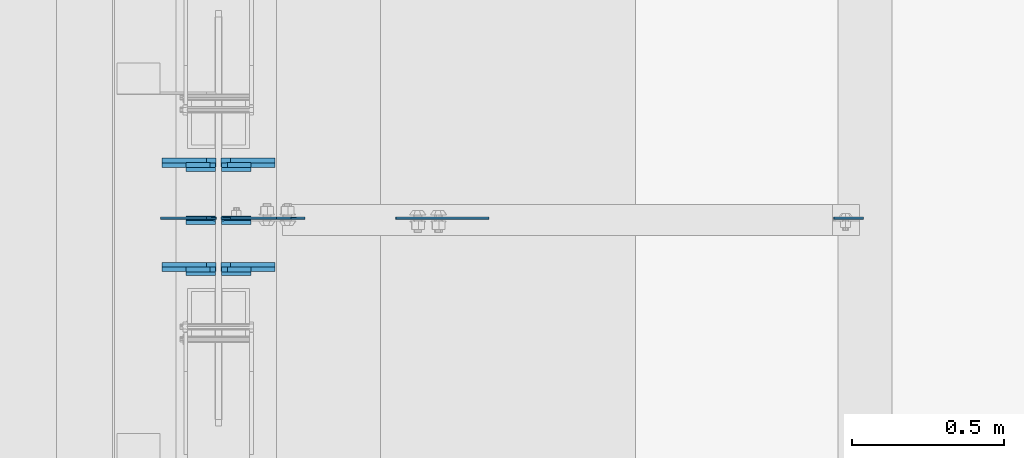
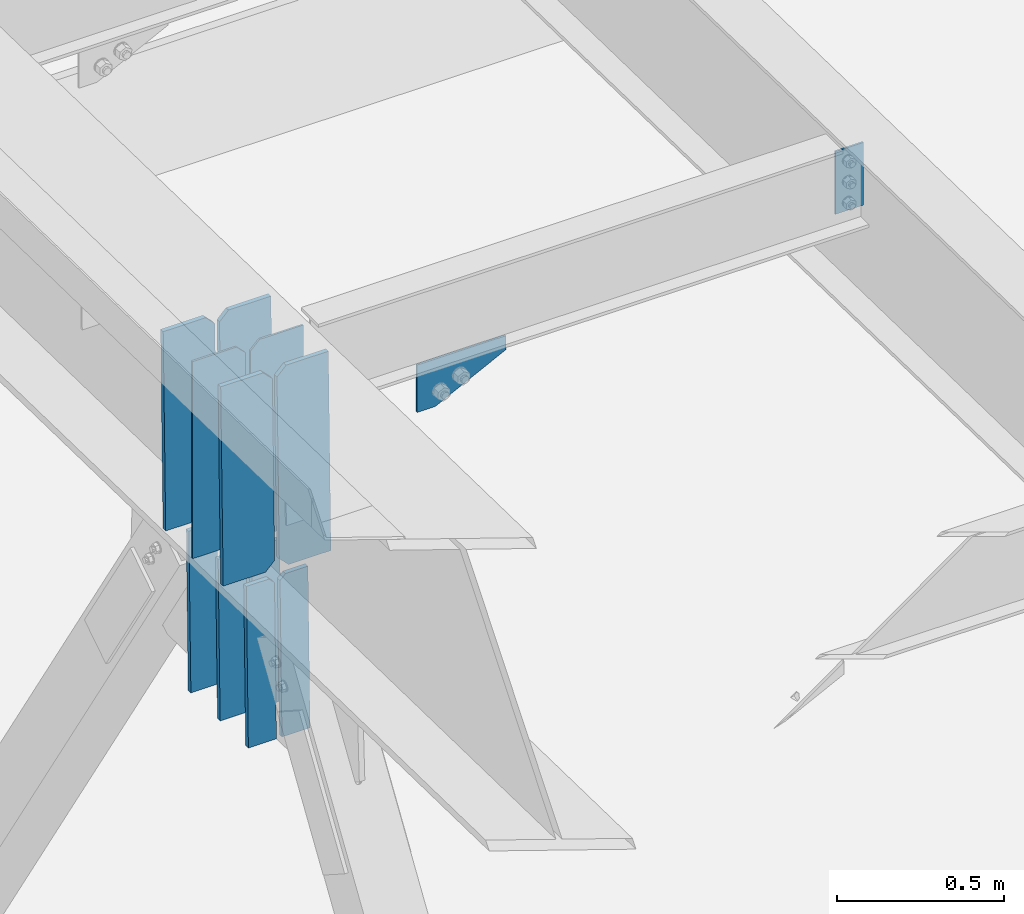
# One storey, part 1435 of 1763: 14 plates, 3 elements without a shape of their own.
"""IFC2X3 building model written with IfcOpenShell, lengths in millimetres."""

from ifc_helpers import new_model, si_unit, frame, origin_with_axes, place, context, subcontext, project, spatial, faceted_brep, material, type_object, element, aggregate, save


model = new_model("IFC2X3")

# Units and contexts
model_context = context("Model", 3, precision=1e-05, world=origin_with_axes())
body_context = subcontext(model_context, "Body", "Model", "MODEL_VIEW")
ifc_project = project(units=[si_unit("LENGTHUNIT", "METRE", prefix="MILLI"), si_unit("AREAUNIT", "SQUARE_METRE"), si_unit("VOLUMEUNIT", "CUBIC_METRE"), si_unit("MASSUNIT", "GRAM", prefix="KILO"), si_unit("TIMEUNIT", "SECOND"), si_unit("PLANEANGLEUNIT", "RADIAN"), si_unit("SOLIDANGLEUNIT", "STERADIAN"), si_unit("THERMODYNAMICTEMPERATUREUNIT", "DEGREE_CELSIUS"), si_unit("LUMINOUSINTENSITYUNIT", "LUMEN")], contexts=[model_context])

# Site, building, storey
site_placement = place(None, origin_with_axes())
site = spatial("IfcSite", under=ifc_project, at=site_placement, CompositionType="ELEMENT")
building_placement = place(site_placement, origin_with_axes())
building = spatial("IfcBuilding", under=site, at=building_placement, Name="Undefined", CompositionType="ELEMENT")
storey_placement = place(building_placement, origin_with_axes())
storey = spatial("IfcBuildingStorey", under=building, at=storey_placement, Name="Undefined", CompositionType="ELEMENT", Elevation=0.0)

# Assembly, plate
assembly_1_placement = place(storey_placement, origin_with_axes())
assembly_1 = element("IfcElementAssembly", 1, at=assembly_1_placement, inside=storey, Name="BEAM", AssemblyPlace="NOTDEFINED", PredefinedType="RIGID_FRAME")
ifc_material = material(Name="STEEL/A36")
plate_type_1 = type_object("IfcPlateType", PredefinedType="NOTDEFINED")
plate_1_placement = place(assembly_1_placement, frame((-85253.8569165555, 4502.14999998664, 11785.8655106812), z_axis=(-1.0, 0.0, 0.0), x_axis=(0.0, 0.0, -1.0)))
plate_1 = element("IfcPlate", 2, at=plate_1_placement, type_object=plate_type_1, material=ifc_material, Name="PLATE", context=body_context, shape_type="Brep", body=[
    faceted_brep([(1.81898940354586e-12, -3.17500000000291, 0.0), (0.0, -3.17499999999927, 96.8375015258789), (0.0, 3.17499999999927, 96.8375015258789), (-1.81898940354586e-12, 3.17499999997381, 0.0), (228.600006103516, -3.17499999999927, 96.8375015258789), (228.600006103516, 3.17499999999927, 96.8375015258789), (228.600006103516, -3.17500000001019, -7.27595761418343e-12), (228.600006103516, 3.17499999999563, -7.27595761418343e-12)], [[[0, 1, 2, 3]], [[1, 4, 5, 2]], [[4, 6, 7, 5]], [[6, 0, 3, 7]], [[5, 7, 3, 2]], [[6, 4, 1, 0]]]),
])
aggregate(assembly_1, [plate_1])

# Assembly, plates
assembly_2_placement = place(storey_placement, origin_with_axes())
assembly_2 = element("IfcElementAssembly", 3, at=assembly_2_placement, inside=storey, Name="BEAM", AssemblyPlace="NOTDEFINED", PredefinedType="RIGID_FRAME")
plate_type_2 = type_object("IfcPlateType", PredefinedType="NOTDEFINED")
plate_2_placement = place(assembly_2_placement, frame((-87383.6747736984, 4502.15000003567, 11077.9107555057), z_axis=(0.0, 0.0, 1.0), x_axis=(-1.0, 0.0, 0.0)))
plate_2 = element("IfcPlate", 4, at=plate_2_placement, type_object=plate_type_2, material=ifc_material, Name="PLATE", context=body_context, shape_type="Brep", body=[
    faceted_brep([(0.0, -3.17500000000291, 31.75), (0.0, -3.17499999999927, 686.812194824219), (0.0, 3.17499999999927, 686.812194824219), (0.0, 3.17500000000291, 31.75), (31.75, -3.17499999999927, 718.562194824219), (31.75, 3.17499999999927, 718.562194824219), (182.5625, -3.17499999999927, 718.562194824219), (182.5625, 3.17499999999927, 718.562194824219), (182.5625, -3.17500000000291, 0.0), (182.5625, 3.17500000000291, 0.0), (31.7499999999036, -3.17499999997381, 9.42916855706244e-11), (31.7499999998854, 3.17500000000291, 9.42916855706244e-11)], [[[0, 1, 2, 3]], [[1, 4, 5, 2]], [[4, 6, 7, 5]], [[6, 8, 9, 7]], [[8, 10, 11, 9]], [[10, 0, 3, 11]], [[5, 7, 9, 11, 3, 2]], [[10, 8, 6, 4, 1, 0]]]),
])
plate_type_3 = type_object("IfcPlateType", PredefinedType="NOTDEFINED")
plate_3_placement = place(assembly_2_placement, frame((-87367.1997736983, 4502.15000003459, 11077.9107555057), z_axis=(0.0, 0.0, 1.0), x_axis=(1.0, 0.0, 0.0)))
plate_3 = element("IfcPlate", 5, at=plate_3_placement, type_object=plate_type_3, material=ifc_material, Name="PLATE", context=body_context, shape_type="Brep", body=[
    faceted_brep([(0.0, -3.17500000000291, 31.75), (0.0, -3.17499999999927, 686.812255859375), (0.0, 3.17499999999927, 686.812255859375), (0.0, 3.17500000000291, 31.75), (31.75, -3.17499999999927, 718.562255859375), (31.75, 3.17499999999927, 718.562255859375), (182.5625, -3.17500000000018, 718.562255859375), (182.5625, 3.17500000000018, 718.562255859375), (182.261993408203, -3.17499999999927, 172.454345703125), (182.261993408203, 3.17499999999927, 172.454345703125), (230.306228637695, -3.17499999999927, 172.454345703125), (230.306228637695, 3.17499999999927, 172.454345703125), (275.743133544922, -3.17499999999927, 81.5805358886719), (275.743133544922, 3.17499999999927, 81.5805358886719), (182.262496948242, -3.17500000000018, 0.0), (182.262496948242, 3.17500000000018, 0.0), (31.7499999999036, -3.17499999997381, 9.42916855706244e-11), (31.7499999998854, 3.17500000000291, 9.42916855706244e-11)], [[[0, 1, 2, 3]], [[1, 4, 5, 2]], [[4, 6, 7, 5]], [[6, 8, 9, 7]], [[8, 10, 11, 9]], [[10, 12, 13, 11]], [[12, 14, 15, 13]], [[14, 16, 17, 15]], [[16, 0, 3, 17]], [[5, 7, 9, 11, 13, 15, 17, 3, 2]], [[16, 14, 12, 10, 8, 6, 4, 1, 0]]]),
])

# Assembly, plate
assembly_3_placement = place(storey_placement, origin_with_axes())
assembly_3 = element("IfcElementAssembly", 6, at=assembly_3_placement, inside=storey, Name="BEAM", AssemblyPlace="NOTDEFINED", PredefinedType="RIGID_FRAME")
plate_type_4 = type_object("IfcPlateType", PredefinedType="NOTDEFINED")
plate_4_placement = place(assembly_3_placement, frame((-86792.4786752764, 4502.14999998671, 11512.8155106838), z_axis=(1.0, 0.0, 0.0), x_axis=(0.0, 0.0, -1.0)))
plate_4 = element("IfcPlate", 7, at=plate_4_placement, type_object=plate_type_4, material=ifc_material, Name="PLATE", context=body_context, shape_type="Brep", body=[
    faceted_brep([(1.81898940354586e-12, -3.17500000000291, 0.0), (0.0, -3.17499999999927, 306.070465087891), (0.0, 3.17499999999927, 306.070465087891), (-1.81898940354586e-12, 3.17499999997381, 0.0), (50.7999992370605, -3.17499999999927, 306.070465087891), (50.7999992370605, 3.17499999999927, 306.070465087891), (172.922760009766, -3.17499999999927, 61.8249359130859), (172.922760009766, 3.17499999999927, 61.8249359130859), (172.922760009766, -3.17499999999927, 0.0), (172.922760009766, 3.17499999999927, 0.0)], [[[0, 1, 2, 3]], [[1, 4, 5, 2]], [[4, 6, 7, 5]], [[6, 8, 9, 7]], [[8, 0, 3, 9]], [[5, 7, 9, 3, 2]], [[8, 6, 4, 1, 0]]]),
])
aggregate(assembly_3, [plate_4])

# Plate
plate_type_5 = type_object("IfcPlateType", PredefinedType="NOTDEFINED")
plate_5_placement = place(assembly_2_placement, frame((-87189.6997736983, 4333.47417978537, 11081.0710497935), z_axis=(0.0, 0.0209013539966291, 0.999781542838788), x_axis=(-1.0, 0.0, 0.0)))
plate_5 = element("IfcPlate", 8, at=plate_5_placement, type_object=plate_type_5, material=ifc_material, Name="PLATE", context=body_context, shape_type="Brep", body=[
    faceted_brep([(-7.27595761418343e-12, -7.9375, 0.0), (0.0, -7.93750000023556, 717.549987793544), (0.0, 7.93749999976308, 717.549987793549), (-7.27595761418343e-12, 7.9375, 0.0), (146.050003051758, -7.93750000023556, 717.549987793544), (146.050003051758, 7.93749999976308, 717.549987793549), (177.800003051758, -7.93750000022555, 685.799987793518), (177.800003051758, 7.93749999977354, 685.799987793525), (177.800003051758, -7.93750000001, 31.7500000000236), (177.800003051758, 7.93749999998863, 31.7500000000309), (146.050003051758, -7.9375, 0.0), (146.050003051758, 7.93749999999909, 3.63797880709171e-12)], [[[0, 1, 2, 3]], [[1, 4, 5, 2]], [[4, 6, 7, 5]], [[6, 8, 9, 7]], [[8, 10, 11, 9]], [[10, 0, 3, 11]], [[5, 7, 9, 11, 3, 2]], [[10, 8, 6, 4, 1, 0]]]),
])

plate_6_placement = place(assembly_2_placement, frame((-87383.3747736983, 4333.47417978537, 11081.0710497935), z_axis=(0.0, 0.0209013539966291, 0.999781542838788), x_axis=(-1.0, 0.0, 0.0)))
plate_6 = element("IfcPlate", 9, at=plate_6_placement, type_object=plate_type_5, material=ifc_material, Name="PLATE", context=body_context, shape_type="Brep", body=[
    faceted_brep([(0.0, -7.9375, 31.75), (0.0, -7.93750000022555, 685.799987793518), (0.0, 7.93749999977354, 685.799987793525), (0.0, 7.9375, 31.75), (31.75, -7.93750000023556, 717.549987793544), (31.75, 7.93749999976262, 717.549987793549), (177.800003051758, -7.93750000023556, 717.549987793544), (177.800003051758, 7.93749999976262, 717.549987793549), (177.800003051758, -7.9375, 0.0), (177.800003051758, 7.93749999999909, 3.63797880709171e-12), (31.75, -7.9375, 0.0), (31.75, 7.9375, 0.0)], [[[0, 1, 2, 3]], [[1, 4, 5, 2]], [[4, 6, 7, 5]], [[6, 8, 9, 7]], [[8, 10, 11, 9]], [[10, 0, 3, 11]], [[5, 7, 9, 11, 3, 2]], [[10, 8, 6, 4, 1, 0]]]),
])

plate_7_placement = place(assembly_2_placement, frame((-87189.6997736983, 4676.76464922385, 11073.8942456565), z_axis=(0.0, 0.0209013539966291, 0.999781542838788), x_axis=(-1.0, 0.0, 0.0)))
plate_7 = element("IfcPlate", 10, at=plate_7_placement, type_object=plate_type_5, material=ifc_material, Name="PLATE", context=body_context, shape_type="Brep", body=[
    faceted_brep([(-7.27595761418343e-12, -7.9375, 0.0), (0.0, -7.93750000023556, 717.549987793544), (0.0, 7.93749999976308, 717.549987793549), (-7.27595761418343e-12, 7.9375, 0.0), (146.050003051758, -7.93750000023556, 717.549987793544), (146.050003051758, 7.93749999976308, 717.549987793549), (177.800003051758, -7.93750000022555, 685.799987793518), (177.800003051758, 7.93749999977354, 685.799987793525), (177.800003051758, -7.93750000001, 31.7500000000236), (177.800003051758, 7.93749999998863, 31.7500000000309), (146.050003051758, -7.9375, 0.0), (146.050003051758, 7.93749999999909, 3.63797880709171e-12)], [[[0, 1, 2, 3]], [[1, 4, 5, 2]], [[4, 6, 7, 5]], [[6, 8, 9, 7]], [[8, 10, 11, 9]], [[10, 0, 3, 11]], [[5, 7, 9, 11, 3, 2]], [[10, 8, 6, 4, 1, 0]]]),
])

plate_8_placement = place(assembly_2_placement, frame((-87383.3747736983, 4676.76464922385, 11073.8942456565), z_axis=(0.0, 0.0209013539966291, 0.999781542838788), x_axis=(-1.0, 0.0, 0.0)))
plate_8 = element("IfcPlate", 11, at=plate_8_placement, type_object=plate_type_5, material=ifc_material, Name="PLATE", context=body_context, shape_type="Brep", body=[
    faceted_brep([(0.0, -7.9375, 31.75), (0.0, -7.93750000022555, 685.799987793518), (0.0, 7.93749999977354, 685.799987793525), (0.0, 7.9375, 31.75), (31.75, -7.93750000023556, 717.549987793544), (31.75, 7.93749999976262, 717.549987793549), (177.800003051758, -7.93750000023556, 717.549987793544), (177.800003051758, 7.93749999976262, 717.549987793549), (177.800003051758, -7.9375, 0.0), (177.800003051758, 7.93749999999909, 3.63797880709171e-12), (31.75, -7.9375, 0.0), (31.75, 7.9375, 0.0)], [[[0, 1, 2, 3]], [[1, 4, 5, 2]], [[4, 6, 7, 5]], [[6, 8, 9, 7]], [[8, 10, 11, 9]], [[10, 0, 3, 11]], [[5, 7, 9, 11, 3, 2]], [[10, 8, 6, 4, 1, 0]]]),
])

plate_type_6 = type_object("IfcPlateType", PredefinedType="NOTDEFINED")
plate_9_placement = place(assembly_2_placement, frame((-87384.9622736979, 4332.8774234315, 11052.5022817547), z_axis=(0.0, -0.0209013569953167, -0.999781542776098), x_axis=(-1.0, 0.0, 0.0)))
plate_9 = element("IfcPlate", 12, at=plate_9_placement, type_object=plate_type_6, material=ifc_material, Name="PLATE", context=body_context, shape_type="Brep", body=[
    faceted_brep([(-3.27418092638254e-10, -7.9375, 19.0499992370605), (0.0, -7.93750000019099, 581.786499023903), (0.0, 7.9374999998081, 581.786499023907), (-3.27418092638254e-10, 7.9375, 19.0499992370605), (96.8374938964844, -7.93750000019099, 581.786499023903), (96.8374938964844, 7.9374999998081, 581.786499023907), (96.8374938964844, -7.93749999999955, 3.63797880709171e-12), (96.8374938964844, 7.93749999999909, 5.45696821063757e-12), (19.0499815529183, -7.9375, 0.0), (19.0499815529183, 7.9375, 0.0)], [[[0, 1, 2, 3]], [[1, 4, 5, 2]], [[4, 6, 7, 5]], [[6, 8, 9, 7]], [[8, 0, 3, 9]], [[5, 7, 9, 3, 2]], [[8, 6, 4, 1, 0]]]),
])

plate_10_placement = place(assembly_2_placement, frame((-87269.0747736981, 4332.87742343012, 11052.50228183), z_axis=(0.0, -0.0209013569953167, -0.999781542776098), x_axis=(-1.0, 0.0, 0.0)))
plate_10 = element("IfcPlate", 13, at=plate_10_placement, type_object=plate_type_6, material=ifc_material, Name="PLATE", context=body_context, shape_type="Brep", body=[
    faceted_brep([(-7.27595761418343e-12, -7.9375, 0.0), (0.0, -7.93750000019099, 581.786499023903), (0.0, 7.9374999998081, 581.786499023907), (-7.27595761418343e-12, 7.9375, 0.0), (96.8374938964844, -7.93750000019099, 581.786499023903), (96.8374938964844, 7.9374999998081, 581.786499023907), (96.8375015258789, -7.93750000000546, 19.0499992370715), (96.8375015258789, 7.93749999999272, 19.0499992370769), (77.7875022888184, -7.93749999999864, -1.81898940354586e-12), (77.7875022888184, 7.93749999999909, 0.0)], [[[0, 1, 2, 3]], [[1, 4, 5, 2]], [[4, 6, 7, 5]], [[6, 8, 9, 7]], [[8, 0, 3, 9]], [[5, 7, 9, 3, 2]], [[8, 6, 4, 1, 0]]]),
])

plate_11_placement = place(assembly_2_placement, frame((-87384.9622736981, 4676.16789300387, 11045.3254779126), z_axis=(0.0, -0.0209013569953167, -0.999781542776098), x_axis=(-1.0, 0.0, 0.0)))
plate_11 = element("IfcPlate", 14, at=plate_11_placement, type_object=plate_type_6, material=ifc_material, Name="PLATE", context=body_context, shape_type="Brep", body=[
    faceted_brep([(-3.27418092638254e-10, -7.9375, 19.0499992370605), (0.0, -7.93750000019099, 581.786499023903), (0.0, 7.9374999998081, 581.786499023907), (-3.27418092638254e-10, 7.9375, 19.0499992370605), (96.8374938964844, -7.93750000019099, 581.786499023903), (96.8374938964844, 7.9374999998081, 581.786499023907), (96.8374938964844, -7.93749999999955, 3.63797880709171e-12), (96.8374938964844, 7.93749999999909, 5.45696821063757e-12), (19.0499815529183, -7.9375, 0.0), (19.0499815529183, 7.9375, 0.0)], [[[0, 1, 2, 3]], [[1, 4, 5, 2]], [[4, 6, 7, 5]], [[6, 8, 9, 7]], [[8, 0, 3, 9]], [[5, 7, 9, 3, 2]], [[8, 6, 4, 1, 0]]]),
])

plate_12_placement = place(assembly_2_placement, frame((-87384.9622736983, 4501.41402241045, 11048.9788710399), z_axis=(0.0, -0.0209013569953167, -0.999781542776098), x_axis=(-1.0, 0.0, 0.0)))
plate_12 = element("IfcPlate", 15, at=plate_12_placement, type_object=plate_type_6, material=ifc_material, Name="PLATE", context=body_context, shape_type="Brep", body=[
    faceted_brep([(-3.27418092638254e-10, -7.9375, 19.0499992370605), (0.0, -7.93749999993724, 581.73303222653), (0.0, 7.93750000006276, 581.733032226542), (-3.27418092638254e-10, 7.9375, 19.0499992370605), (96.8374938964844, -7.93749999993724, 581.73303222653), (96.8374938964844, 7.93750000006276, 581.733032226542), (96.8374938964844, -7.93749999999955, 3.63797880709171e-12), (96.8374938964844, 7.93749999999909, 5.45696821063757e-12), (19.0499815529183, -7.9375, 0.0), (19.0499815529183, 7.9375, 0.0)], [[[0, 1, 2, 3]], [[1, 4, 5, 2]], [[4, 6, 7, 5]], [[6, 8, 9, 7]], [[8, 0, 3, 9]], [[5, 7, 9, 3, 2]], [[8, 6, 4, 1, 0]]]),
])

plate_13_placement = place(assembly_2_placement, frame((-87269.0747736981, 4676.16789300387, 11045.3254779126), z_axis=(0.0, -0.0209013569953167, -0.999781542776098), x_axis=(-1.0, 0.0, 0.0)))
plate_13 = element("IfcPlate", 16, at=plate_13_placement, type_object=plate_type_6, material=ifc_material, Name="PLATE", context=body_context, shape_type="Brep", body=[
    faceted_brep([(-7.27595761418343e-12, -7.9375, 0.0), (0.0, -7.93750000019099, 581.786499023903), (0.0, 7.9374999998081, 581.786499023907), (-7.27595761418343e-12, 7.9375, 0.0), (96.8374938964844, -7.93750000019099, 581.786499023903), (96.8374938964844, 7.9374999998081, 581.786499023907), (96.8375015258789, -7.93750000000546, 19.0499992370715), (96.8375015258789, 7.93749999999272, 19.0499992370769), (77.7875022888184, -7.93749999999864, -1.81898940354586e-12), (77.7875022888184, 7.93749999999909, 0.0)], [[[0, 1, 2, 3]], [[1, 4, 5, 2]], [[4, 6, 7, 5]], [[6, 8, 9, 7]], [[8, 0, 3, 9]], [[5, 7, 9, 3, 2]], [[8, 6, 4, 1, 0]]]),
])

plate_14_placement = place(assembly_2_placement, frame((-87269.0747736983, 4501.41402241044, 11048.9788710399), z_axis=(0.0, -0.0209013569953167, -0.999781542776098), x_axis=(-1.0, 0.0, 0.0)))
plate_14 = element("IfcPlate", 17, at=plate_14_placement, type_object=plate_type_6, material=ifc_material, Name="PLATE", context=body_context, shape_type="Brep", body=[
    faceted_brep([(-7.27595761418343e-12, -7.9375, 0.0), (0.0, -7.93749999993724, 581.73303222653), (0.0, 7.93750000006276, 581.733032226542), (-7.27595761418343e-12, 7.9375, 0.0), (96.8374938964844, -7.93749999993724, 581.73303222653), (96.8374938964844, 7.93750000006276, 581.733032226542), (96.8375015258789, -7.93750000000546, 19.0499992370715), (96.8375015258789, 7.93749999999272, 19.0499992370769), (77.7875022888184, -7.93749999999864, -1.81898940354586e-12), (77.7875022888184, 7.93749999999909, 0.0)], [[[0, 1, 2, 3]], [[1, 4, 5, 2]], [[4, 6, 7, 5]], [[6, 8, 9, 7]], [[8, 0, 3, 9]], [[5, 7, 9, 3, 2]], [[8, 6, 4, 1, 0]]]),
])

aggregate(assembly_2, [plate_2, plate_3, plate_5, plate_6, plate_7, plate_8, plate_9, plate_10, plate_11, plate_12, plate_13, plate_14])

save(model, "model.ifc")
